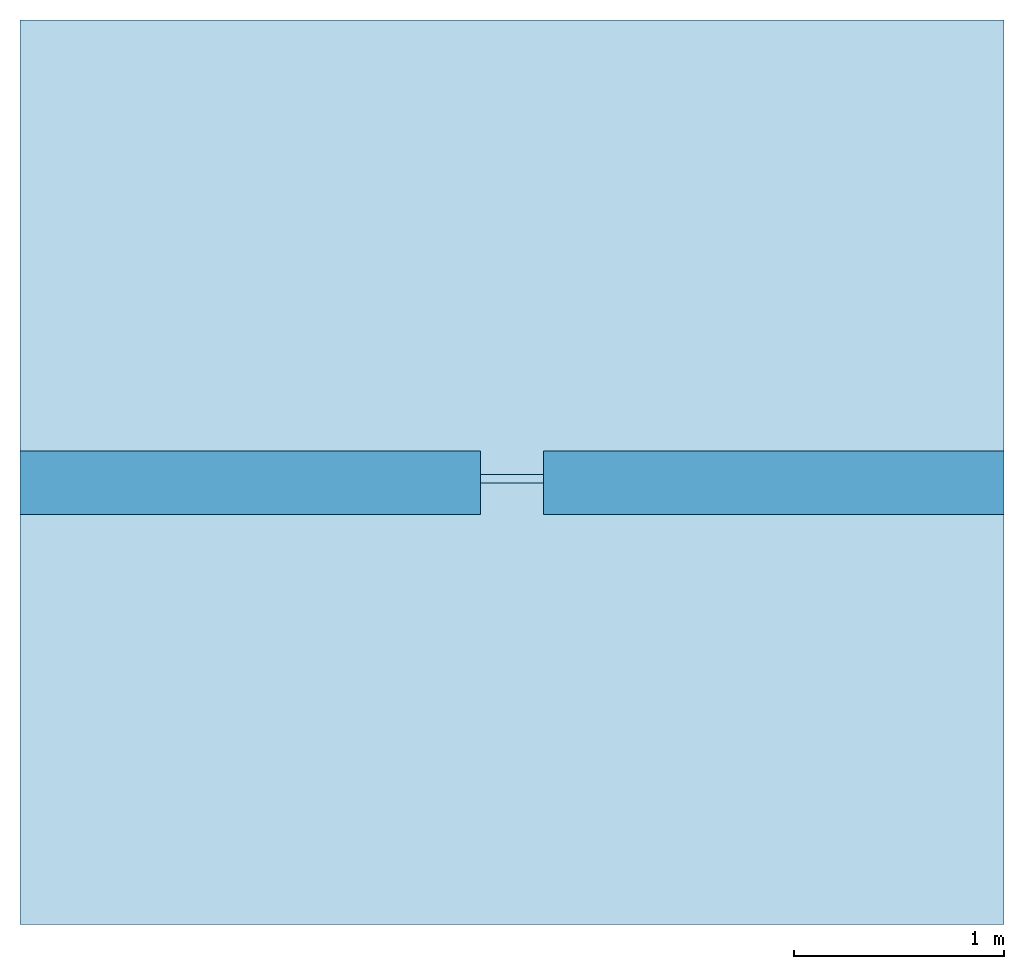
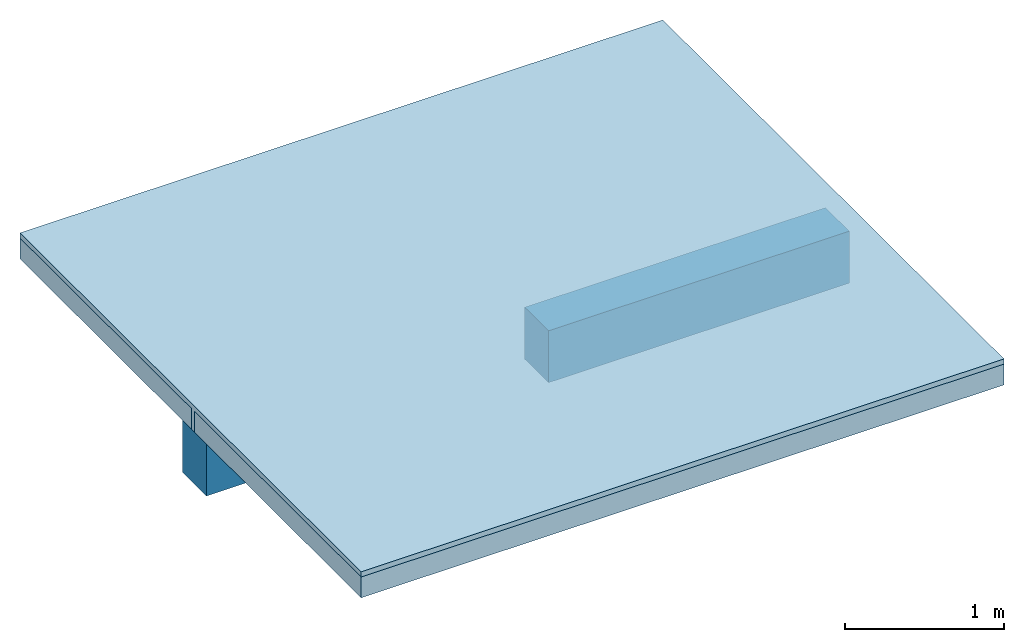
# One storey: 2 beams, 2 slabs.
"""IFC4 building model written with IfcOpenShell, lengths in centimetres."""

from ifc_helpers import new_model, si_unit, frame, origin_with_axes, place, context, subcontext, project, spatial, polygons, source, transform, mapped, element, save


model = new_model("IFC4")

# Units and contexts
model_context = context("Model", 3, precision=1e-05, world=origin_with_axes())
plan_context = context("Plan", 2, precision=1e-05, world=origin_with_axes())
body_context = subcontext(model_context, "Body", "Model", "MODEL_VIEW")
ifc_project = project(units=[si_unit("LENGTHUNIT", "METRE", prefix="CENTI"), si_unit("AREAUNIT", "SQUARE_METRE", prefix="CENTI"), si_unit("VOLUMEUNIT", "CUBIC_METRE", prefix="CENTI")], contexts=[model_context, plan_context])

# Site, building, storey
site_placement = place(None, frame((1288.70067596436, 2573.25820922852, 0.0), z_axis=(0.0, 0.0, 1.0), x_axis=(1.0, 0.0, 0.0)))
site = spatial("IfcSite", under=ifc_project, at=site_placement)
building_placement = place(site_placement, origin_with_axes())
building = spatial("IfcBuilding", under=site, at=building_placement, Name="Default")
storey_placement = place(building_placement, frame((0.0, 0.0, 300.0), z_axis=(0.0, 0.0, 1.0), x_axis=(1.0, 0.0, 0.0)))
storey = spatial("IfcBuildingStorey", under=building, at=storey_placement, Name="1")

# Beams
shared_shape_1 = source(origin_with_axes(), body_context, "Body", "Tessellation", [
    polygons([(505.816986083984, 139.517532348633, 280.0), (724.719299316406, 139.517532348633, 280.0), (505.816986083984, 139.517532348633, 240.000015258789), (724.719299316406, 139.517532348633, 240.000015258789), (505.816986083984, 169.517547607422, 240.000015258789), (724.719299316406, 169.517547607422, 240.000015258789), (505.816986083984, 169.517547607422, 280.0), (724.719299316406, 169.517547607422, 280.0)], [[[8, 6, 5, 7]], [[2, 8, 7, 1]], [[7, 5, 3, 1]], [[6, 8, 2, 4]], [[4, 2, 1, 3]], [[6, 4, 3, 5]]]),
])
beam_1_placement = place(storey_placement, frame((9.5367431640625e-05, 0.00019073486328125, -300.0), z_axis=(0.0, 0.0, 1.0), x_axis=(1.0, 0.0, 0.0)))
element("IfcBeam", 1, at=beam_1_placement, inside=storey, Name="Poutre - balk", PredefinedType="BEAM", context=body_context, shape_type="MappedRepresentation", body=[
    mapped(shared_shape_1, transform((0.0, 0.0, 0.0), x_axis=(1.0, 0.0, 0.0), y_axis=(0.0, 1.0, 0.0), z_axis=(0.0, 0.0, 1.0), scale=1.0)),
])
shared_shape_2 = source(origin_with_axes(), body_context, "Body", "Tessellation", [
    polygons([(475.816955566406, 169.517547607422, 280.0), (256.914672851563, 169.517547607422, 280.0), (475.816955566406, 169.517547607422, 240.000015258789), (256.914672851563, 169.517547607422, 240.000015258789), (475.816955566406, 139.517532348633, 240.000015258789), (256.914672851563, 139.517532348633, 240.000015258789), (475.816955566406, 139.517532348633, 280.0), (256.914672851563, 139.517532348633, 280.0)], [[[8, 6, 5, 7]], [[2, 8, 7, 1]], [[7, 5, 3, 1]], [[6, 8, 2, 4]], [[4, 2, 1, 3]], [[6, 4, 3, 5]]]),
])
beam_2_placement = place(storey_placement, frame((9.5367431640625e-05, 0.00019073486328125, -300.0), z_axis=(0.0, 0.0, 1.0), x_axis=(1.0, 0.0, 0.0)))
element("IfcBeam", 2, at=beam_2_placement, inside=storey, Name="Poutre - balk", PredefinedType="BEAM", context=body_context, shape_type="MappedRepresentation", body=[
    mapped(shared_shape_2, transform((0.0, 0.0, 0.0), x_axis=(1.0, 0.0, 0.0), y_axis=(0.0, 1.0, 0.0), z_axis=(0.0, 0.0, 1.0), scale=1.0)),
])

# Slabs
shared_shape_3 = source(origin_with_axes(), body_context, "Body", "Tessellation", [
    polygons([(256.914672851563, -55.4824600219727, -20.0), (256.914672851563, -55.4824600219727, -4.0), (724.719299316406, -55.4824600219727, -20.0), (724.719299316406, -55.4824600219727, -4.0), (724.719299316406, 154.517547607422, -20.0), (724.719299316406, 154.517547607422, -4.0), (256.914672851563, 154.517547607422, -20.0), (256.914672851563, 154.517547607422, -4.0), (724.719299316406, 374.517547607422, -20.0), (724.719299316406, 374.517547607422, -4.0), (256.914672851563, 374.517547607422, -20.0), (256.914672851563, 374.517547607422, -4.0), (256.914672851563, 158.517532348633, -20.0), (256.914672851563, 158.517532348633, -4.0), (724.719299316406, 158.517532348633, -20.0), (724.719299316406, 158.517532348633, -4.0)], [[[6, 4, 3, 5]], [[8, 6, 5, 7]], [[2, 8, 7, 1]], [[1, 7, 5, 3]], [[6, 8, 2, 4]], [[12, 10, 9, 11]], [[14, 12, 11, 13]], [[16, 14, 13, 15]], [[10, 16, 15, 9]], [[9, 15, 13, 11]], [[14, 16, 10, 12]], [[4, 2, 1, 3]]]),
])
slab_1_placement = place(storey_placement, frame((9.5367431640625e-05, 0.00019073486328125, 0.0), z_axis=(0.0, 0.0, 1.0), x_axis=(1.0, 0.0, 0.0)))
element("IfcSlab", 3, at=slab_1_placement, inside=storey, PredefinedType="FLOOR", context=body_context, shape_type="MappedRepresentation", body=[
    mapped(shared_shape_3, transform((0.0, 0.0, 0.0), x_axis=(1.0, 0.0, 0.0), y_axis=(0.0, 1.0, 0.0), z_axis=(0.0, 0.0, 1.0), scale=1.0)),
])
shared_shape_4 = source(origin_with_axes(), body_context, "Body", "Tessellation", [
    polygons([(256.914672851563, -55.4824600219727, -4.0), (724.719299316406, -55.4824600219727, -4.0), (256.914672851563, -55.4824600219727, -3.66096042370145e-12), (724.719299316406, -55.4824600219727, -3.66096042370145e-12), (256.914672851563, 374.517547607422, -2.33008057293205e-12), (724.719299316406, 374.517547607422, -2.33008057293205e-12), (256.914672851563, 374.517547607422, -4.0), (724.719299316406, 374.517547607422, -4.0), (256.914672851563, 158.517532348633, -4.0), (724.719299316406, 158.517532348633, -4.0), (256.914672851563, 158.517532348633, -20.0), (724.719299316406, 158.517532348633, -20.0), (256.914672851563, 154.517547607422, -20.0), (724.719299316406, 154.517547607422, -20.0), (256.914672851563, 154.517547607422, -4.0), (724.719299316406, 154.517547607422, -4.0)], [[[4, 6, 5, 3]], [[6, 8, 7, 5]], [[8, 10, 9, 7]], [[10, 12, 11, 9]], [[12, 14, 13, 11]], [[14, 16, 15, 13]], [[16, 2, 1, 15]], [[15, 9, 11, 13]], [[15, 1, 3]], [[9, 15, 3]], [[10, 16, 14, 12]], [[5, 9, 3]], [[7, 9, 5]], [[4, 2, 16]], [[4, 16, 10]], [[4, 10, 6]], [[6, 10, 8]], [[2, 4, 3, 1]]]),
])
slab_2_placement = place(storey_placement, frame((9.5367431640625e-05, 0.00019073486328125, 0.0), z_axis=(0.0, 0.0, 1.0), x_axis=(1.0, 0.0, 0.0)))
element("IfcSlab", 4, at=slab_2_placement, inside=storey, Name="Chape de compression", PredefinedType="FLOOR", context=body_context, shape_type="MappedRepresentation", body=[
    mapped(shared_shape_4, transform((0.0, 0.0, 0.0), x_axis=(1.0, 0.0, 0.0), y_axis=(0.0, 1.0, 0.0), z_axis=(0.0, 0.0, 1.0), scale=1.0)),
])

save(model, "model.ifc")
